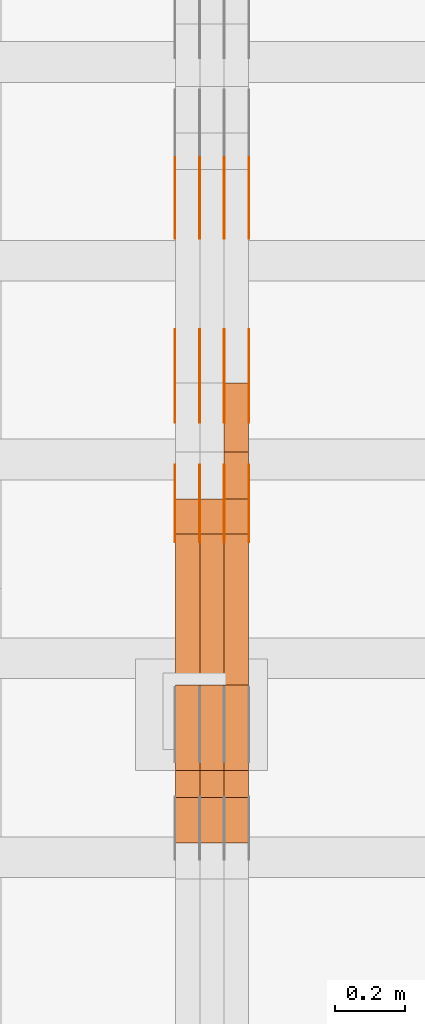
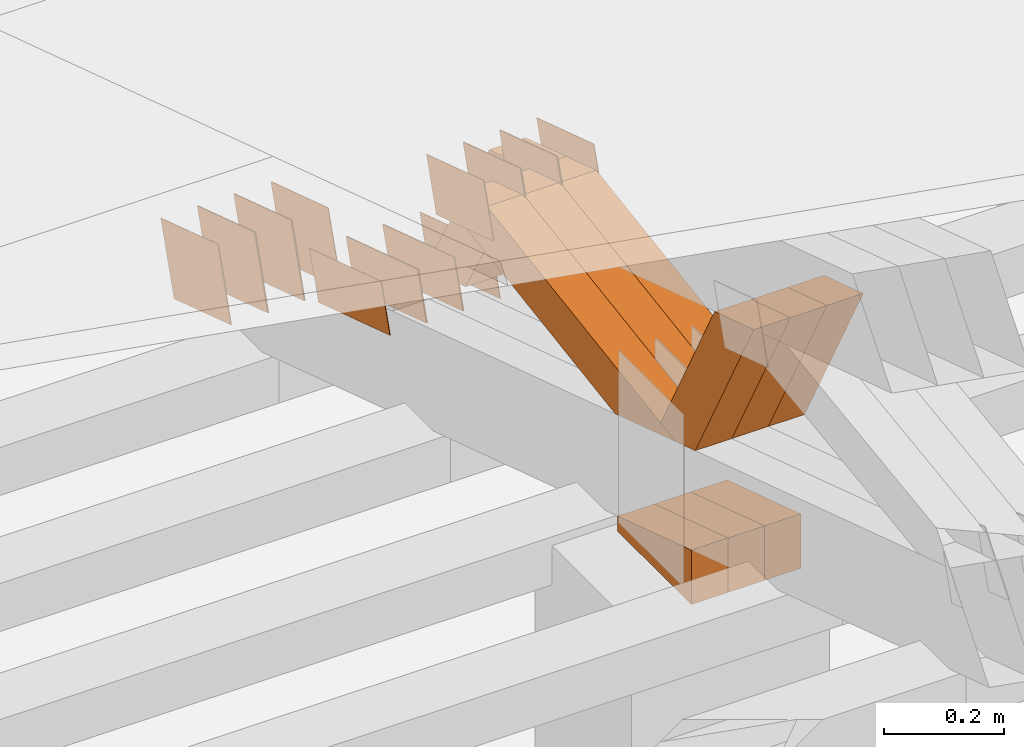
# One storey, part 293 of 385: 28 proxies.
"""IFC2X3 building model written with IfcOpenShell, lengths in millimetres."""

from ifc_helpers import new_model, entity, si_unit, converted_unit, derived_unit, direction, frame, origin, place, context, subcontext, project, spatial, polyline, outline, extrude, source, transform, mapped, material, type_object, type_shapes, element, save


model = new_model("IFC2X3")

# Units and contexts
model_context = context("Model", 3, precision=0.01, world=origin(), true_north=direction((6.12303176911189e-17, 1.0)))
body_context = subcontext(model_context, "Body", "Model", "MODEL_VIEW")
ifc_project = project(units=[si_unit("LENGTHUNIT", "METRE", prefix="MILLI"), si_unit("AREAUNIT", "SQUARE_METRE"), si_unit("VOLUMEUNIT", "CUBIC_METRE"), converted_unit("PLANEANGLEUNIT", "DEGREE", entity("IfcRatioMeasure", 0.0174532925199433), si_unit("PLANEANGLEUNIT", "RADIAN"), dimensions=[0, 0, 0, 0, 0, 0, 0]), si_unit("MASSUNIT", "GRAM", prefix="KILO"), derived_unit("MASSDENSITYUNIT", [(si_unit("MASSUNIT", "GRAM", prefix="KILO"), 1), (si_unit("LENGTHUNIT", "METRE"), -3)]), si_unit("TIMEUNIT", "SECOND"), si_unit("FREQUENCYUNIT", "HERTZ"), si_unit("THERMODYNAMICTEMPERATUREUNIT", "DEGREE_CELSIUS"), derived_unit("THERMALTRANSMITTANCEUNIT", [(si_unit("MASSUNIT", "GRAM", prefix="KILO"), 1), (si_unit("THERMODYNAMICTEMPERATUREUNIT", "KELVIN"), -1), (si_unit("TIMEUNIT", "SECOND"), -3)]), derived_unit("VOLUMETRICFLOWRATEUNIT", [(si_unit("LENGTHUNIT", "METRE"), 3), (si_unit("TIMEUNIT", "SECOND"), -1)]), si_unit("ELECTRICCURRENTUNIT", "AMPERE"), si_unit("ELECTRICVOLTAGEUNIT", "VOLT"), si_unit("POWERUNIT", "WATT"), si_unit("FORCEUNIT", "NEWTON", prefix="KILO"), si_unit("ILLUMINANCEUNIT", "LUX"), si_unit("LUMINOUSFLUXUNIT", "LUMEN"), si_unit("LUMINOUSINTENSITYUNIT", "CANDELA"), derived_unit("USERDEFINED", [(si_unit("MASSUNIT", "GRAM", prefix="KILO"), -1), (si_unit("LENGTHUNIT", "METRE"), -2), (si_unit("TIMEUNIT", "SECOND"), 3), (si_unit("LUMINOUSFLUXUNIT", "LUMEN"), 1)]), derived_unit("LINEARVELOCITYUNIT", [(si_unit("LENGTHUNIT", "METRE"), 1), (si_unit("TIMEUNIT", "SECOND"), -1)]), si_unit("PRESSUREUNIT", "PASCAL"), derived_unit("USERDEFINED", [(si_unit("LENGTHUNIT", "METRE"), -2), (si_unit("MASSUNIT", "GRAM", prefix="KILO"), 1), (si_unit("TIMEUNIT", "SECOND"), -2)])], contexts=[model_context])

# Site, building, storey
site_placement = place(None, origin())
site = spatial("IfcSite", under=ifc_project, at=site_placement, CompositionType="ELEMENT")
building_placement = place(site_placement, origin())
building = spatial("IfcBuilding", under=site, at=building_placement, CompositionType="ELEMENT")
storey_placement = place(building_placement, origin())
storey = spatial("IfcBuildingStorey", under=building, at=storey_placement, Name="Default", CompositionType="ELEMENT", Elevation=0.0)

# Proxies
ifc_material_1 = material(Name="IfcSurfaceStyle #480150")
building_element_proxy_type_1 = type_object("IfcBuildingElementProxyType", PredefinedType="NOTDEFINED", material=ifc_material_1)
shared_shape_1 = source(origin(), body_context, "Body", "SweptSolid", [
    extrude(outline(polyline([(-125.00031378339, -47.9999612158856), (125.000225258022, -47.9999612158856), (124.999811678525, 47.9999612158856), (-124.999723153156, 47.9999612158856), (-125.00031378339, -47.9999612158856)])), frame((125.000225258022, 48.0000091013474, 0.0), z_axis=(0.0, 0.0, 1.0), x_axis=(-1.0, 0.0, 0.0)), (0.0, 0.0, 1.0), 1.3),
])
type_shapes(building_element_proxy_type_1, [shared_shape_1])
proxy_1_placement = place(building_placement, frame((39386.3, 18456.8597683375, 2657.46691321253), z_axis=(-1.0, 0.0, 0.0), x_axis=(0.0, -0.951056516295124, 0.309016994375039)))
element("IfcBuildingElementProxy", 1, at=proxy_1_placement, inside=storey, type_object=building_element_proxy_type_1, material=ifc_material_1, context=body_context, shape_type="MappedRepresentation", body=[
    mapped(shared_shape_1, transform((0.0, 0.0, 0.0), scale=1.0)),
])
ifc_material_2 = material(Name="IfcSurfaceStyle #480093")
building_element_proxy_type_2 = type_object("IfcBuildingElementProxyType", PredefinedType="NOTDEFINED", material=ifc_material_2)
shared_shape_2 = source(origin(), body_context, "Body", "SweptSolid", [
    extrude(outline(polyline([(-125.00031378339, -47.9999612158856), (125.000225258022, -47.9999612158856), (124.999811678525, 47.9999612158856), (-124.999723153156, 47.9999612158856), (-125.00031378339, -47.9999612158856)])), frame((125.000225258022, 48.0000091013474, 0.0), z_axis=(0.0, 0.0, 1.0), x_axis=(-1.0, 0.0, 0.0)), (0.0, 0.0, 1.0), 1.3),
])
type_shapes(building_element_proxy_type_2, [shared_shape_2])
proxy_2_placement = place(building_placement, frame((39315.0, 18456.8597683375, 2657.46691321253), z_axis=(-1.0, 0.0, 0.0), x_axis=(0.0, -0.951056516295124, 0.309016994375039)))
element("IfcBuildingElementProxy", 2, at=proxy_2_placement, inside=storey, type_object=building_element_proxy_type_2, material=ifc_material_2, context=body_context, shape_type="MappedRepresentation", body=[
    mapped(shared_shape_2, transform((0.0, 0.0, 0.0), scale=1.0)),
])
ifc_material_3 = material(Name="IfcSurfaceStyle #480036")
building_element_proxy_type_3 = type_object("IfcBuildingElementProxyType", PredefinedType="NOTDEFINED", material=ifc_material_3)
shared_shape_3 = source(origin(), body_context, "Body", "SweptSolid", [
    extrude(outline(polyline([(-125.00031378339, -47.9999612158856), (125.000225258022, -47.9999612158856), (124.999811678525, 47.9999612158856), (-124.999723153156, 47.9999612158856), (-125.00031378339, -47.9999612158856)])), frame((125.000225258022, 48.0000091013474, 0.0), z_axis=(0.0, 0.0, 1.0), x_axis=(-1.0, 0.0, 0.0)), (0.0, 0.0, 1.0), 1.3),
])
type_shapes(building_element_proxy_type_3, [shared_shape_3])
proxy_3_placement = place(building_placement, frame((39316.3, 18456.8597683375, 2657.46691321253), z_axis=(-1.0, 0.0, 0.0), x_axis=(0.0, -0.951056516295124, 0.309016994375039)))
element("IfcBuildingElementProxy", 3, at=proxy_3_placement, inside=storey, type_object=building_element_proxy_type_3, material=ifc_material_3, context=body_context, shape_type="MappedRepresentation", body=[
    mapped(shared_shape_3, transform((0.0, 0.0, 0.0), scale=1.0)),
])
ifc_material_4 = material(Name="IfcSurfaceStyle #479979")
building_element_proxy_type_4 = type_object("IfcBuildingElementProxyType", PredefinedType="NOTDEFINED", material=ifc_material_4)
shared_shape_4 = source(origin(), body_context, "Body", "SweptSolid", [
    extrude(outline(polyline([(-125.00031378339, -47.9999612158856), (125.000225258022, -47.9999612158856), (124.999811678525, 47.9999612158856), (-124.999723153156, 47.9999612158856), (-125.00031378339, -47.9999612158856)])), frame((125.000225258022, 48.0000091013474, 0.0), z_axis=(0.0, 0.0, 1.0), x_axis=(-1.0, 0.0, 0.0)), (0.0, 0.0, 1.0), 1.29999999999998),
])
type_shapes(building_element_proxy_type_4, [shared_shape_4])
proxy_4_placement = place(building_placement, frame((39245.0, 18456.8597683375, 2657.46691321253), z_axis=(-1.0, 0.0, 0.0), x_axis=(0.0, -0.951056516295124, 0.309016994375039)))
element("IfcBuildingElementProxy", 4, at=proxy_4_placement, inside=storey, type_object=building_element_proxy_type_4, material=ifc_material_4, context=body_context, shape_type="MappedRepresentation", body=[
    mapped(shared_shape_4, transform((0.0, 0.0, 0.0), scale=1.0)),
])
ifc_material_5 = material(Name="IfcSurfaceStyle #479922")
building_element_proxy_type_5 = type_object("IfcBuildingElementProxyType", PredefinedType="NOTDEFINED", material=ifc_material_5)
shared_shape_5 = source(origin(), body_context, "Body", "SweptSolid", [
    extrude(outline(polyline([(-125.00031378339, -47.9999612158856), (125.000225258022, -47.9999612158856), (124.999811678525, 47.9999612158856), (-124.999723153156, 47.9999612158856), (-125.00031378339, -47.9999612158856)])), frame((125.000225258022, 48.0000091013474, 0.0), z_axis=(0.0, 0.0, 1.0), x_axis=(-1.0, 0.0, 0.0)), (0.0, 0.0, 1.0), 1.29999999999998),
])
type_shapes(building_element_proxy_type_5, [shared_shape_5])
proxy_5_placement = place(building_placement, frame((39246.3, 18456.8597683375, 2657.46691321253), z_axis=(-1.0, 0.0, 0.0), x_axis=(0.0, -0.951056516295124, 0.309016994375039)))
element("IfcBuildingElementProxy", 5, at=proxy_5_placement, inside=storey, type_object=building_element_proxy_type_5, material=ifc_material_5, context=body_context, shape_type="MappedRepresentation", body=[
    mapped(shared_shape_5, transform((0.0, 0.0, 0.0), scale=1.0)),
])
ifc_material_6 = material(Name="IfcSurfaceStyle #479865")
building_element_proxy_type_6 = type_object("IfcBuildingElementProxyType", PredefinedType="NOTDEFINED", material=ifc_material_6)
shared_shape_6 = source(origin(), body_context, "Body", "SweptSolid", [
    extrude(outline(polyline([(-125.00031378339, -47.9999612158856), (125.000225258022, -47.9999612158856), (124.999811678525, 47.9999612158856), (-124.999723153156, 47.9999612158856), (-125.00031378339, -47.9999612158856)])), frame((125.000225258022, 48.0000091013474, 0.0), z_axis=(0.0, 0.0, 1.0), x_axis=(-1.0, 0.0, 0.0)), (0.0, 0.0, 1.0), 1.29999999999998),
])
type_shapes(building_element_proxy_type_6, [shared_shape_6])
proxy_6_placement = place(building_placement, frame((39175.0, 18456.8597683375, 2657.46691321253), z_axis=(-1.0, 0.0, 0.0), x_axis=(0.0, -0.951056516295124, 0.309016994375039)))
element("IfcBuildingElementProxy", 6, at=proxy_6_placement, inside=storey, type_object=building_element_proxy_type_6, material=ifc_material_6, context=body_context, shape_type="MappedRepresentation", body=[
    mapped(shared_shape_6, transform((0.0, 0.0, 0.0), scale=1.0)),
])
ifc_material_7 = material(Name="IfcSurfaceStyle #478440")
building_element_proxy_type_7 = type_object("IfcBuildingElementProxyType", PredefinedType="NOTDEFINED", material=ifc_material_7)
shared_shape_7 = source(origin(), body_context, "Body", "SweptSolid", [
    extrude(outline(polyline([(-99.999796294464, -72.0000050220467), (99.9998768370438, -72.0000050220467), (100.000260677528, 72.0000050220467), (-100.000341220108, 72.0000050220467), (-99.999796294464, -72.0000050220467)])), frame((100.000260677528, 72.0000050220467, 0.0), z_axis=(0.0, 0.0, 1.0), x_axis=(-1.0, 0.0, 0.0)), (0.0, 0.0, 1.0), 1.3),
])
type_shapes(building_element_proxy_type_7, [shared_shape_7])
proxy_7_placement = place(building_placement, frame((39386.3, 18936.3876569477, 2373.90613192527), z_axis=(-1.0, 0.0, 0.0), x_axis=(0.0, -0.951056516295124, 0.309016994375039)))
element("IfcBuildingElementProxy", 7, at=proxy_7_placement, inside=storey, type_object=building_element_proxy_type_7, material=ifc_material_7, context=body_context, shape_type="MappedRepresentation", body=[
    mapped(shared_shape_7, transform((0.0, 0.0, 0.0), scale=1.0)),
])
ifc_material_8 = material(Name="IfcSurfaceStyle #478383")
building_element_proxy_type_8 = type_object("IfcBuildingElementProxyType", PredefinedType="NOTDEFINED", material=ifc_material_8)
shared_shape_8 = source(origin(), body_context, "Body", "SweptSolid", [
    extrude(outline(polyline([(-99.999796294464, -72.0000050220467), (99.9998768370438, -72.0000050220467), (100.000260677528, 72.0000050220467), (-100.000341220108, 72.0000050220467), (-99.999796294464, -72.0000050220467)])), frame((100.000260677528, 72.0000050220467, 0.0), z_axis=(0.0, 0.0, 1.0), x_axis=(-1.0, 0.0, 0.0)), (0.0, 0.0, 1.0), 1.3),
])
type_shapes(building_element_proxy_type_8, [shared_shape_8])
proxy_8_placement = place(building_placement, frame((39315.0, 18936.3876569477, 2373.90613192527), z_axis=(-1.0, 0.0, 0.0), x_axis=(0.0, -0.951056516295124, 0.309016994375039)))
element("IfcBuildingElementProxy", 8, at=proxy_8_placement, inside=storey, type_object=building_element_proxy_type_8, material=ifc_material_8, context=body_context, shape_type="MappedRepresentation", body=[
    mapped(shared_shape_8, transform((0.0, 0.0, 0.0), scale=1.0)),
])
ifc_material_9 = material(Name="IfcSurfaceStyle #478326")
building_element_proxy_type_9 = type_object("IfcBuildingElementProxyType", PredefinedType="NOTDEFINED", material=ifc_material_9)
shared_shape_9 = source(origin(), body_context, "Body", "SweptSolid", [
    extrude(outline(polyline([(-99.999796294464, -72.0000050220467), (99.9998768370438, -72.0000050220467), (100.000260677528, 72.0000050220467), (-100.000341220108, 72.0000050220467), (-99.999796294464, -72.0000050220467)])), frame((100.000260677528, 72.0000050220467, 0.0), z_axis=(0.0, 0.0, 1.0), x_axis=(-1.0, 0.0, 0.0)), (0.0, 0.0, 1.0), 1.3),
])
type_shapes(building_element_proxy_type_9, [shared_shape_9])
proxy_9_placement = place(building_placement, frame((39316.3, 18936.3876569477, 2373.90613192527), z_axis=(-1.0, 0.0, 0.0), x_axis=(0.0, -0.951056516295124, 0.309016994375039)))
element("IfcBuildingElementProxy", 9, at=proxy_9_placement, inside=storey, type_object=building_element_proxy_type_9, material=ifc_material_9, context=body_context, shape_type="MappedRepresentation", body=[
    mapped(shared_shape_9, transform((0.0, 0.0, 0.0), scale=1.0)),
])
ifc_material_10 = material(Name="IfcSurfaceStyle #478269")
building_element_proxy_type_10 = type_object("IfcBuildingElementProxyType", PredefinedType="NOTDEFINED", material=ifc_material_10)
shared_shape_10 = source(origin(), body_context, "Body", "SweptSolid", [
    extrude(outline(polyline([(-99.999796294464, -72.0000050220467), (99.9998768370438, -72.0000050220467), (100.000260677528, 72.0000050220467), (-100.000341220108, 72.0000050220467), (-99.999796294464, -72.0000050220467)])), frame((100.000260677528, 72.0000050220467, 0.0), z_axis=(0.0, 0.0, 1.0), x_axis=(-1.0, 0.0, 0.0)), (0.0, 0.0, 1.0), 1.29999999999998),
])
type_shapes(building_element_proxy_type_10, [shared_shape_10])
proxy_10_placement = place(building_placement, frame((39245.0, 18936.3876569477, 2373.90613192527), z_axis=(-1.0, 0.0, 0.0), x_axis=(0.0, -0.951056516295124, 0.309016994375039)))
element("IfcBuildingElementProxy", 10, at=proxy_10_placement, inside=storey, type_object=building_element_proxy_type_10, material=ifc_material_10, context=body_context, shape_type="MappedRepresentation", body=[
    mapped(shared_shape_10, transform((0.0, 0.0, 0.0), scale=1.0)),
])
ifc_material_11 = material(Name="IfcSurfaceStyle #478212")
building_element_proxy_type_11 = type_object("IfcBuildingElementProxyType", PredefinedType="NOTDEFINED", material=ifc_material_11)
shared_shape_11 = source(origin(), body_context, "Body", "SweptSolid", [
    extrude(outline(polyline([(-99.999796294464, -72.0000050220467), (99.9998768370438, -72.0000050220467), (100.000260677528, 72.0000050220467), (-100.000341220108, 72.0000050220467), (-99.999796294464, -72.0000050220467)])), frame((100.000260677528, 72.0000050220467, 0.0), z_axis=(0.0, 0.0, 1.0), x_axis=(-1.0, 0.0, 0.0)), (0.0, 0.0, 1.0), 1.29999999999998),
])
type_shapes(building_element_proxy_type_11, [shared_shape_11])
proxy_11_placement = place(building_placement, frame((39246.3, 18936.3876569477, 2373.90613192527), z_axis=(-1.0, 0.0, 0.0), x_axis=(0.0, -0.951056516295124, 0.309016994375039)))
element("IfcBuildingElementProxy", 11, at=proxy_11_placement, inside=storey, type_object=building_element_proxy_type_11, material=ifc_material_11, context=body_context, shape_type="MappedRepresentation", body=[
    mapped(shared_shape_11, transform((0.0, 0.0, 0.0), scale=1.0)),
])
ifc_material_12 = material(Name="IfcSurfaceStyle #478155")
building_element_proxy_type_12 = type_object("IfcBuildingElementProxyType", PredefinedType="NOTDEFINED", material=ifc_material_12)
shared_shape_12 = source(origin(), body_context, "Body", "SweptSolid", [
    extrude(outline(polyline([(-99.999796294464, -72.0000050220467), (99.9998768370438, -72.0000050220467), (100.000260677528, 72.0000050220467), (-100.000341220108, 72.0000050220467), (-99.999796294464, -72.0000050220467)])), frame((100.000260677528, 72.0000050220467, 0.0), z_axis=(0.0, 0.0, 1.0), x_axis=(-1.0, 0.0, 0.0)), (0.0, 0.0, 1.0), 1.29999999999999),
])
type_shapes(building_element_proxy_type_12, [shared_shape_12])
proxy_12_placement = place(building_placement, frame((39175.0, 18936.3876569477, 2373.90613192527), z_axis=(-1.0, 0.0, 0.0), x_axis=(0.0, -0.951056516295124, 0.309016994375039)))
element("IfcBuildingElementProxy", 12, at=proxy_12_placement, inside=storey, type_object=building_element_proxy_type_12, material=ifc_material_12, context=body_context, shape_type="MappedRepresentation", body=[
    mapped(shared_shape_12, transform((0.0, 0.0, 0.0), scale=1.0)),
])
ifc_material_13 = material(Name="IfcSurfaceStyle #473994")
building_element_proxy_type_13 = type_object("IfcBuildingElementProxyType", PredefinedType="NOTDEFINED", material=ifc_material_13)
shared_shape_13 = source(origin(), body_context, "Body", "SweptSolid", [
    extrude(outline(polyline([(-99.9999427841299, -54.0000599375792), (99.9996549037756, -54.0000599375792), (100.000407167194, 54.0000599375792), (-100.00011928684, 54.0000599375792), (-99.9999427841299, -54.0000599375792)])), frame((100.000407167194, 54.0000599375792, 0.0), z_axis=(0.0, 0.0, 1.0), x_axis=(-1.0, 0.0, 0.0)), (0.0, 0.0, 1.0), 1.3),
])
type_shapes(building_element_proxy_type_13, [shared_shape_13])
proxy_13_placement = place(building_placement, frame((39386.3, 18065.0682492591, 3072.55239547302), z_axis=(-1.0, 0.0, 0.0), x_axis=(0.0, -0.951056516295154, 0.309016994374948)))
element("IfcBuildingElementProxy", 13, at=proxy_13_placement, inside=storey, type_object=building_element_proxy_type_13, material=ifc_material_13, context=body_context, shape_type="MappedRepresentation", body=[
    mapped(shared_shape_13, transform((0.0, 0.0, 0.0), scale=1.0)),
])
ifc_material_14 = material(Name="IfcSurfaceStyle #473937")
building_element_proxy_type_14 = type_object("IfcBuildingElementProxyType", PredefinedType="NOTDEFINED", material=ifc_material_14)
shared_shape_14 = source(origin(), body_context, "Body", "SweptSolid", [
    extrude(outline(polyline([(-99.9999427841299, -54.0000599375792), (99.9996549037756, -54.0000599375792), (100.000407167194, 54.0000599375792), (-100.00011928684, 54.0000599375792), (-99.9999427841299, -54.0000599375792)])), frame((100.000407167194, 54.0000599375792, 0.0), z_axis=(0.0, 0.0, 1.0), x_axis=(-1.0, 0.0, 0.0)), (0.0, 0.0, 1.0), 1.3),
])
type_shapes(building_element_proxy_type_14, [shared_shape_14])
proxy_14_placement = place(building_placement, frame((39315.0, 18065.0682492591, 3072.55239547302), z_axis=(-1.0, 0.0, 0.0), x_axis=(0.0, -0.951056516295154, 0.309016994374948)))
element("IfcBuildingElementProxy", 14, at=proxy_14_placement, inside=storey, type_object=building_element_proxy_type_14, material=ifc_material_14, context=body_context, shape_type="MappedRepresentation", body=[
    mapped(shared_shape_14, transform((0.0, 0.0, 0.0), scale=1.0)),
])
ifc_material_15 = material(Name="IfcSurfaceStyle #473880")
building_element_proxy_type_15 = type_object("IfcBuildingElementProxyType", PredefinedType="NOTDEFINED", material=ifc_material_15)
shared_shape_15 = source(origin(), body_context, "Body", "SweptSolid", [
    extrude(outline(polyline([(-99.9999427841299, -54.0000599375792), (99.9996549037756, -54.0000599375792), (100.000407167194, 54.0000599375792), (-100.00011928684, 54.0000599375792), (-99.9999427841299, -54.0000599375792)])), frame((100.000407167194, 54.0000599375792, 0.0), z_axis=(0.0, 0.0, 1.0), x_axis=(-1.0, 0.0, 0.0)), (0.0, 0.0, 1.0), 1.3),
])
type_shapes(building_element_proxy_type_15, [shared_shape_15])
proxy_15_placement = place(building_placement, frame((39316.3, 18065.0682492591, 3072.55239547302), z_axis=(-1.0, 0.0, 0.0), x_axis=(0.0, -0.951056516295154, 0.309016994374948)))
element("IfcBuildingElementProxy", 15, at=proxy_15_placement, inside=storey, type_object=building_element_proxy_type_15, material=ifc_material_15, context=body_context, shape_type="MappedRepresentation", body=[
    mapped(shared_shape_15, transform((0.0, 0.0, 0.0), scale=1.0)),
])
ifc_material_16 = material(Name="IfcSurfaceStyle #473823")
building_element_proxy_type_16 = type_object("IfcBuildingElementProxyType", PredefinedType="NOTDEFINED", material=ifc_material_16)
shared_shape_16 = source(origin(), body_context, "Body", "SweptSolid", [
    extrude(outline(polyline([(-99.9999427841299, -54.0000599375792), (99.9996549037756, -54.0000599375792), (100.000407167194, 54.0000599375792), (-100.00011928684, 54.0000599375792), (-99.9999427841299, -54.0000599375792)])), frame((100.000407167194, 54.0000599375792, 0.0), z_axis=(0.0, 0.0, 1.0), x_axis=(-1.0, 0.0, 0.0)), (0.0, 0.0, 1.0), 1.29999999999998),
])
type_shapes(building_element_proxy_type_16, [shared_shape_16])
proxy_16_placement = place(building_placement, frame((39245.0, 18065.0682492591, 3072.55239547302), z_axis=(-1.0, 0.0, 0.0), x_axis=(0.0, -0.951056516295154, 0.309016994374948)))
element("IfcBuildingElementProxy", 16, at=proxy_16_placement, inside=storey, type_object=building_element_proxy_type_16, material=ifc_material_16, context=body_context, shape_type="MappedRepresentation", body=[
    mapped(shared_shape_16, transform((0.0, 0.0, 0.0), scale=1.0)),
])
ifc_material_17 = material(Name="IfcSurfaceStyle #473766")
building_element_proxy_type_17 = type_object("IfcBuildingElementProxyType", PredefinedType="NOTDEFINED", material=ifc_material_17)
shared_shape_17 = source(origin(), body_context, "Body", "SweptSolid", [
    extrude(outline(polyline([(-99.9999427841299, -54.0000599375792), (99.9996549037756, -54.0000599375792), (100.000407167194, 54.0000599375792), (-100.00011928684, 54.0000599375792), (-99.9999427841299, -54.0000599375792)])), frame((100.000407167194, 54.0000599375792, 0.0), z_axis=(0.0, 0.0, 1.0), x_axis=(-1.0, 0.0, 0.0)), (0.0, 0.0, 1.0), 1.29999999999998),
])
type_shapes(building_element_proxy_type_17, [shared_shape_17])
proxy_17_placement = place(building_placement, frame((39246.3, 18065.0682492591, 3072.55239547302), z_axis=(-1.0, 0.0, 0.0), x_axis=(0.0, -0.951056516295154, 0.309016994374948)))
element("IfcBuildingElementProxy", 17, at=proxy_17_placement, inside=storey, type_object=building_element_proxy_type_17, material=ifc_material_17, context=body_context, shape_type="MappedRepresentation", body=[
    mapped(shared_shape_17, transform((0.0, 0.0, 0.0), scale=1.0)),
])
ifc_material_18 = material(Name="IfcSurfaceStyle #473709")
building_element_proxy_type_18 = type_object("IfcBuildingElementProxyType", PredefinedType="NOTDEFINED", material=ifc_material_18)
shared_shape_18 = source(origin(), body_context, "Body", "SweptSolid", [
    extrude(outline(polyline([(-99.9999427841299, -54.0000599375792), (99.9996549037756, -54.0000599375792), (100.000407167194, 54.0000599375792), (-100.00011928684, 54.0000599375792), (-99.9999427841299, -54.0000599375792)])), frame((100.000407167194, 54.0000599375792, 0.0), z_axis=(0.0, 0.0, 1.0), x_axis=(-1.0, 0.0, 0.0)), (0.0, 0.0, 1.0), 1.29999999999999),
])
type_shapes(building_element_proxy_type_18, [shared_shape_18])
proxy_18_placement = place(building_placement, frame((39175.0, 18065.0682492591, 3072.55239547302), z_axis=(-1.0, 0.0, 0.0), x_axis=(0.0, -0.951056516295154, 0.309016994374948)))
element("IfcBuildingElementProxy", 18, at=proxy_18_placement, inside=storey, type_object=building_element_proxy_type_18, material=ifc_material_18, context=body_context, shape_type="MappedRepresentation", body=[
    mapped(shared_shape_18, transform((0.0, 0.0, 0.0), scale=1.0)),
])
ifc_material_19 = material(Name="IfcSurfaceStyle #466389")
building_element_proxy_type_19 = type_object("IfcBuildingElementProxyType", Name="T1-E1 466387", PredefinedType="NOTDEFINED", material=ifc_material_19)
shared_shape_19 = source(origin(), body_context, "Body", "SweptSolid", [
    extrude(outline(polyline([(4.4675903320374, -122.500000000001), (35.3350219726624, -122.500000000001), (35.3350219726501, 122.500000000001), (-75.1376342773499, 122.500000000001), (4.4675903320374, -122.500000000001)])), frame((35.3350219726624, 122.50000005215, 0.0), z_axis=(0.0, 0.0, 1.0), x_axis=(-1.0, 0.0, 0.0)), (0.0, 0.0, 1.0), 70.0),
])
type_shapes(building_element_proxy_type_19, [shared_shape_19])
proxy_19_placement = place(building_placement, frame((39385.0, 17220.0, 2794.30932617186), z_axis=(-1.0, 0.0, 0.0), x_axis=(0.0, 0.0, 1.0)))
element("IfcBuildingElementProxy", 19, at=proxy_19_placement, inside=storey, type_object=building_element_proxy_type_19, material=ifc_material_19, Name="T1-E1", context=body_context, shape_type="MappedRepresentation", body=[
    mapped(shared_shape_19, transform((0.0, 0.0, 0.0), scale=1.0)),
])
ifc_material_20 = material(Name="IfcSurfaceStyle #466332")
building_element_proxy_type_20 = type_object("IfcBuildingElementProxyType", Name="T1-E1 466330", PredefinedType="NOTDEFINED", material=ifc_material_20)
shared_shape_20 = source(origin(), body_context, "Body", "SweptSolid", [
    extrude(outline(polyline([(4.4675903320374, -122.500000000001), (35.3350219726624, -122.500000000001), (35.3350219726501, 122.500000000001), (-75.1376342773499, 122.500000000001), (4.4675903320374, -122.500000000001)])), frame((35.3350219726624, 122.50000005215, 0.0), z_axis=(0.0, 0.0, 1.0), x_axis=(-1.0, 0.0, 0.0)), (0.0, 0.0, 1.0), 70.0),
])
type_shapes(building_element_proxy_type_20, [shared_shape_20])
proxy_20_placement = place(building_placement, frame((39315.0, 17220.0, 2794.30932617186), z_axis=(-1.0, 0.0, 0.0), x_axis=(0.0, 0.0, 1.0)))
element("IfcBuildingElementProxy", 20, at=proxy_20_placement, inside=storey, type_object=building_element_proxy_type_20, material=ifc_material_20, Name="T1-E1", context=body_context, shape_type="MappedRepresentation", body=[
    mapped(shared_shape_20, transform((0.0, 0.0, 0.0), scale=1.0)),
])
ifc_material_21 = material(Name="IfcSurfaceStyle #466275")
building_element_proxy_type_21 = type_object("IfcBuildingElementProxyType", Name="T1-E1 466273", PredefinedType="NOTDEFINED", material=ifc_material_21)
shared_shape_21 = source(origin(), body_context, "Body", "SweptSolid", [
    extrude(outline(polyline([(4.4675903320374, -122.500000000001), (35.3350219726624, -122.500000000001), (35.3350219726501, 122.500000000001), (-75.1376342773499, 122.500000000001), (4.4675903320374, -122.500000000001)])), frame((35.3350219726624, 122.50000005215, 0.0), z_axis=(0.0, 0.0, 1.0), x_axis=(-1.0, 0.0, 0.0)), (0.0, 0.0, 1.0), 70.0),
])
type_shapes(building_element_proxy_type_21, [shared_shape_21])
proxy_21_placement = place(building_placement, frame((39245.0, 17220.0, 2794.30932617186), z_axis=(-1.0, 0.0, 0.0), x_axis=(0.0, 0.0, 1.0)))
element("IfcBuildingElementProxy", 21, at=proxy_21_placement, inside=storey, type_object=building_element_proxy_type_21, material=ifc_material_21, Name="T1-E1", context=body_context, shape_type="MappedRepresentation", body=[
    mapped(shared_shape_21, transform((0.0, 0.0, 0.0), scale=1.0)),
])
ifc_material_22 = material(Name="IfcSurfaceStyle #464634")
building_element_proxy_type_22 = type_object("IfcBuildingElementProxyType", Name="T1-W39 464632", PredefinedType="NOTDEFINED", material=ifc_material_22)
shared_shape_22 = source(origin(), body_context, "Body", "SweptSolid", [
    extrude(outline(polyline([(-191.519946663886, -47.499928106579), (188.32936223763, -47.499928106579), (171.597440144109, 0.000249483340993841), (122.102882529753, 47.4998033649085), (-290.509738247605, 47.4998033649085), (-191.519946663886, -47.499928106579)])), frame((188.329593252001, 47.499957247623, 0.0), z_axis=(0.0, 0.0, 1.0), x_axis=(-1.0, 0.0, 0.0)), (0.0, 0.0, 1.0), 70.0),
])
type_shapes(building_element_proxy_type_22, [shared_shape_22])
proxy_22_placement = place(building_placement, frame((39385.0, 17238.5876916597, 3055.56121424762), z_axis=(-1.0, 0.0, 0.0), x_axis=(0.0, -0.472216932390777, 0.881482370080902)))
element("IfcBuildingElementProxy", 22, at=proxy_22_placement, inside=storey, type_object=building_element_proxy_type_22, material=ifc_material_22, Name="T1-W39", context=body_context, shape_type="MappedRepresentation", body=[
    mapped(shared_shape_22, transform((0.0, 0.0, 0.0), scale=1.0)),
])
ifc_material_23 = material(Name="IfcSurfaceStyle #464568")
building_element_proxy_type_23 = type_object("IfcBuildingElementProxyType", Name="T1-W39 464566", PredefinedType="NOTDEFINED", material=ifc_material_23)
shared_shape_23 = source(origin(), body_context, "Body", "SweptSolid", [
    extrude(outline(polyline([(-191.519946663886, -47.499928106579), (188.32936223763, -47.499928106579), (171.597440144109, 0.000249483340993841), (122.102882529753, 47.4998033649085), (-290.509738247605, 47.4998033649085), (-191.519946663886, -47.499928106579)])), frame((188.329593252001, 47.499957247623, 0.0), z_axis=(0.0, 0.0, 1.0), x_axis=(-1.0, 0.0, 0.0)), (0.0, 0.0, 1.0), 70.0),
])
type_shapes(building_element_proxy_type_23, [shared_shape_23])
proxy_23_placement = place(building_placement, frame((39315.0, 17238.5876916597, 3055.56121424762), z_axis=(-1.0, 0.0, 0.0), x_axis=(0.0, -0.472216932390777, 0.881482370080902)))
element("IfcBuildingElementProxy", 23, at=proxy_23_placement, inside=storey, type_object=building_element_proxy_type_23, material=ifc_material_23, Name="T1-W39", context=body_context, shape_type="MappedRepresentation", body=[
    mapped(shared_shape_23, transform((0.0, 0.0, 0.0), scale=1.0)),
])
ifc_material_24 = material(Name="IfcSurfaceStyle #464502")
building_element_proxy_type_24 = type_object("IfcBuildingElementProxyType", Name="T1-W39 464500", PredefinedType="NOTDEFINED", material=ifc_material_24)
shared_shape_24 = source(origin(), body_context, "Body", "SweptSolid", [
    extrude(outline(polyline([(-191.519946663886, -47.499928106579), (188.32936223763, -47.499928106579), (171.597440144109, 0.000249483340993841), (122.102882529753, 47.4998033649085), (-290.509738247605, 47.4998033649085), (-191.519946663886, -47.499928106579)])), frame((188.329593252001, 47.499957247623, 0.0), z_axis=(0.0, 0.0, 1.0), x_axis=(-1.0, 0.0, 0.0)), (0.0, 0.0, 1.0), 70.0),
])
type_shapes(building_element_proxy_type_24, [shared_shape_24])
proxy_24_placement = place(building_placement, frame((39245.0, 17238.5876916597, 3055.56121424762), z_axis=(-1.0, 0.0, 0.0), x_axis=(0.0, -0.472216932390777, 0.881482370080902)))
element("IfcBuildingElementProxy", 24, at=proxy_24_placement, inside=storey, type_object=building_element_proxy_type_24, material=ifc_material_24, Name="T1-W39", context=body_context, shape_type="MappedRepresentation", body=[
    mapped(shared_shape_24, transform((0.0, 0.0, 0.0), scale=1.0)),
])
ifc_material_25 = material(Name="IfcSurfaceStyle #464238")
building_element_proxy_type_25 = type_object("IfcBuildingElementProxyType", Name="T1-W10 464236", PredefinedType="NOTDEFINED", material=ifc_material_25)
shared_shape_25 = source(origin(), body_context, "Body", "SweptSolid", [
    extrude(outline(polyline([(-459.546036710757, -47.5000436364511), (174.689450869018, -47.5000436364511), (268.831081103959, 0.00011114562912502), (287.286350706789, 47.4999880636365), (-271.260845969009, 47.4999880636366), (-459.546036710757, -47.5000436364511)])), frame((287.286768781132, 47.5001637448091, 0.0), z_axis=(0.0, 0.0, 1.0), x_axis=(-1.0, 0.0, 0.0)), (0.0, 0.0, 1.0), 70.0),
])
type_shapes(building_element_proxy_type_25, [shared_shape_25])
proxy_25_placement = place(building_placement, frame((39385.0, 18025.1410649788, 3112.76453857986), z_axis=(-1.0, 0.0, 0.0), x_axis=(0.0, -0.988299196256916, -0.152527698068035)))
element("IfcBuildingElementProxy", 25, at=proxy_25_placement, inside=storey, type_object=building_element_proxy_type_25, material=ifc_material_25, Name="T1-W10", context=body_context, shape_type="MappedRepresentation", body=[
    mapped(shared_shape_25, transform((0.0, 0.0, 0.0), scale=1.0)),
])
ifc_material_26 = material(Name="IfcSurfaceStyle #464172")
building_element_proxy_type_26 = type_object("IfcBuildingElementProxyType", Name="T1-W10 464170", PredefinedType="NOTDEFINED", material=ifc_material_26)
shared_shape_26 = source(origin(), body_context, "Body", "SweptSolid", [
    extrude(outline(polyline([(-459.546036710757, -47.5000436364511), (174.689450869018, -47.5000436364511), (268.831081103959, 0.00011114562912502), (287.286350706789, 47.4999880636365), (-271.260845969009, 47.4999880636366), (-459.546036710757, -47.5000436364511)])), frame((287.286768781132, 47.5001637448091, 0.0), z_axis=(0.0, 0.0, 1.0), x_axis=(-1.0, 0.0, 0.0)), (0.0, 0.0, 1.0), 70.0),
])
type_shapes(building_element_proxy_type_26, [shared_shape_26])
proxy_26_placement = place(building_placement, frame((39315.0, 18025.1410649788, 3112.76453857986), z_axis=(-1.0, 0.0, 0.0), x_axis=(0.0, -0.988299196256916, -0.152527698068035)))
element("IfcBuildingElementProxy", 26, at=proxy_26_placement, inside=storey, type_object=building_element_proxy_type_26, material=ifc_material_26, Name="T1-W10", context=body_context, shape_type="MappedRepresentation", body=[
    mapped(shared_shape_26, transform((0.0, 0.0, 0.0), scale=1.0)),
])
ifc_material_27 = material(Name="IfcSurfaceStyle #464106")
building_element_proxy_type_27 = type_object("IfcBuildingElementProxyType", Name="T1-W10 464104", PredefinedType="NOTDEFINED", material=ifc_material_27)
shared_shape_27 = source(origin(), body_context, "Body", "SweptSolid", [
    extrude(outline(polyline([(-459.546036710757, -47.5000436364511), (174.689450869018, -47.5000436364511), (268.831081103959, 0.00011114562912502), (287.286350706789, 47.4999880636365), (-271.260845969009, 47.4999880636366), (-459.546036710757, -47.5000436364511)])), frame((287.286768781132, 47.5001637448091, 0.0), z_axis=(0.0, 0.0, 1.0), x_axis=(-1.0, 0.0, 0.0)), (0.0, 0.0, 1.0), 70.0),
])
type_shapes(building_element_proxy_type_27, [shared_shape_27])
proxy_27_placement = place(building_placement, frame((39245.0, 18025.1410649788, 3112.76453857986), z_axis=(-1.0, 0.0, 0.0), x_axis=(0.0, -0.988299196256916, -0.152527698068035)))
element("IfcBuildingElementProxy", 27, at=proxy_27_placement, inside=storey, type_object=building_element_proxy_type_27, material=ifc_material_27, Name="T1-W10", context=body_context, shape_type="MappedRepresentation", body=[
    mapped(shared_shape_27, transform((0.0, 0.0, 0.0), scale=1.0)),
])
ifc_material_28 = material(Name="IfcSurfaceStyle #463842")
building_element_proxy_type_28 = type_object("IfcBuildingElementProxyType", Name="T1-W35 463840", PredefinedType="NOTDEFINED", material=ifc_material_28)
shared_shape_28 = source(origin(), body_context, "Body", "SweptSolid", [
    extrude(outline(polyline([(-196.877231354918, -47.499850828051), (197.289756738813, -47.499850828051), (177.380838136073, -0.000131002767018074), (124.615181369032, 47.4999163294346), (-302.408544889, 47.4999163294346), (-196.877231354918, -47.499850828051)])), frame((197.289756738813, 47.5002438363521, 0.0), z_axis=(0.0, 0.0, 1.0), x_axis=(-1.0, 0.0, 0.0)), (0.0, 0.0, 1.0), 70.0),
])
type_shapes(building_element_proxy_type_28, [shared_shape_28])
proxy_28_placement = place(building_placement, frame((39385.0, 18249.5528960018, 2724.16980022534), z_axis=(-1.0, 0.0, 0.0), x_axis=(0.0, -0.5, 0.866025403784439)))
element("IfcBuildingElementProxy", 28, at=proxy_28_placement, inside=storey, type_object=building_element_proxy_type_28, material=ifc_material_28, Name="T1-W35", context=body_context, shape_type="MappedRepresentation", body=[
    mapped(shared_shape_28, transform((0.0, 0.0, 0.0), scale=1.0)),
])

save(model, "model.ifc")
